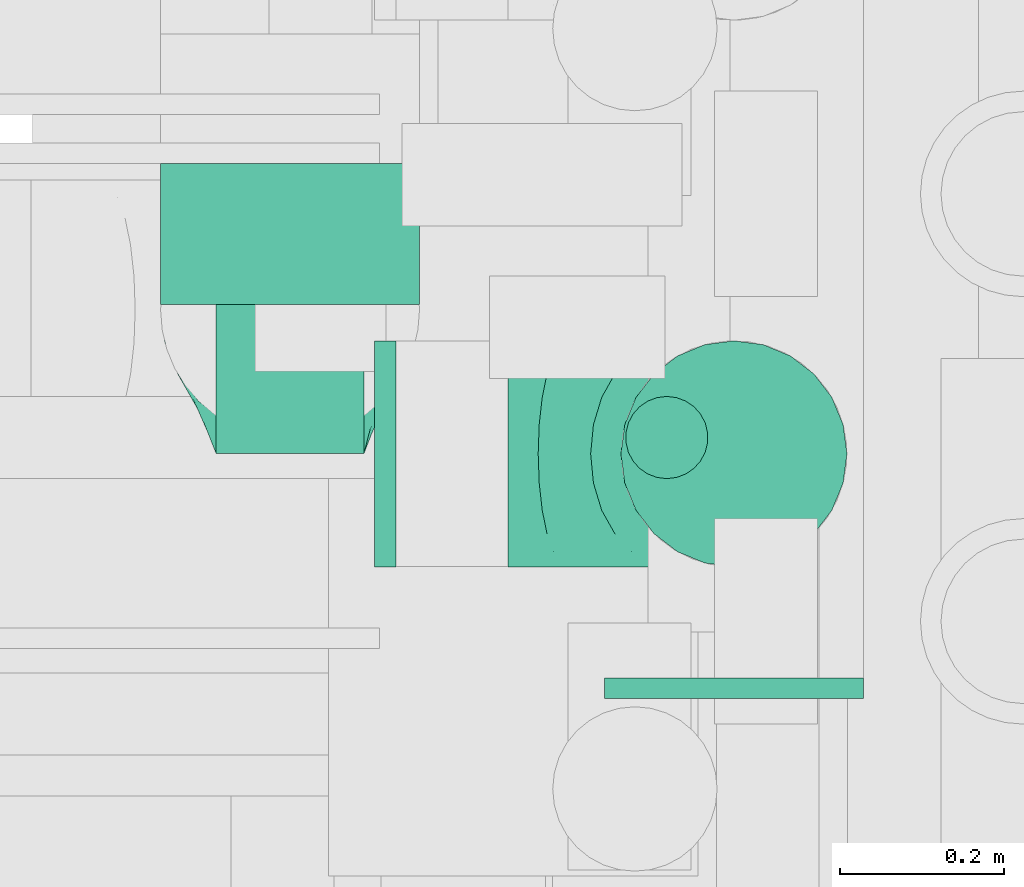
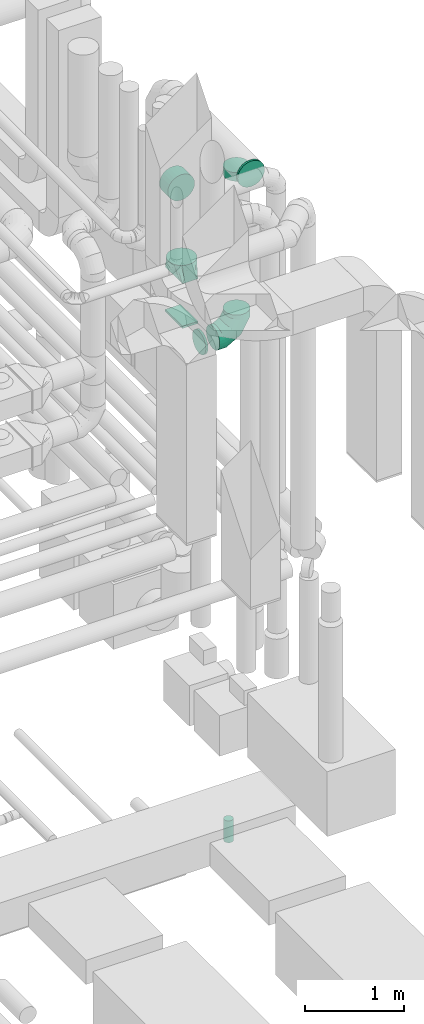
# One storey, part 306 of 337: 7 flow fittings, 1 flow segment.
"""IFC2X3 building model written with IfcOpenShell, lengths in millimetres."""

from ifc_helpers import new_model, entity, si_unit, converted_unit, derived_unit, direction, frame, origin, origin_2d_with_axis, place, context, subcontext, project, spatial, rectangle, circle, extrude, faceted_brep, source, transform, mapped, material, type_object, type_shapes, element, save


model = new_model("IFC2X3")

# Units and contexts
model_context = context("Model", 3, precision=0.01, world=origin(), true_north=direction((6.12303176911189e-17, 1.0)))
body_context = subcontext(model_context, "Body", "Model", "MODEL_VIEW")
ifc_project = project(units=[si_unit("LENGTHUNIT", "METRE", prefix="MILLI"), si_unit("AREAUNIT", "SQUARE_METRE"), si_unit("VOLUMEUNIT", "CUBIC_METRE"), converted_unit("PLANEANGLEUNIT", "DEGREE", entity("IfcRatioMeasure", 0.0174532925199433), si_unit("PLANEANGLEUNIT", "RADIAN"), dimensions=[0, 0, 0, 0, 0, 0, 0]), si_unit("MASSUNIT", "GRAM", prefix="KILO"), derived_unit("MASSDENSITYUNIT", [(si_unit("MASSUNIT", "GRAM", prefix="KILO"), 1), (si_unit("LENGTHUNIT", "METRE"), -3)]), derived_unit("MOMENTOFINERTIAUNIT", [(si_unit("LENGTHUNIT", "METRE"), 4)]), si_unit("TIMEUNIT", "SECOND"), si_unit("FREQUENCYUNIT", "HERTZ"), si_unit("THERMODYNAMICTEMPERATUREUNIT", "DEGREE_CELSIUS"), derived_unit("THERMALTRANSMITTANCEUNIT", [(si_unit("MASSUNIT", "GRAM", prefix="KILO"), 1), (si_unit("THERMODYNAMICTEMPERATUREUNIT", "KELVIN"), -1), (si_unit("TIMEUNIT", "SECOND"), -3)]), derived_unit("VOLUMETRICFLOWRATEUNIT", [(si_unit("LENGTHUNIT", "METRE"), 3), (si_unit("TIMEUNIT", "SECOND"), -1)]), derived_unit("MASSFLOWRATEUNIT", [(si_unit("MASSUNIT", "GRAM", prefix="KILO"), 1), (si_unit("TIMEUNIT", "SECOND"), -1)]), derived_unit("ROTATIONALFREQUENCYUNIT", [(si_unit("TIMEUNIT", "SECOND"), -1)]), si_unit("ELECTRICCURRENTUNIT", "AMPERE"), si_unit("ELECTRICVOLTAGEUNIT", "VOLT"), si_unit("POWERUNIT", "WATT"), si_unit("FORCEUNIT", "NEWTON", prefix="KILO"), si_unit("ILLUMINANCEUNIT", "LUX"), si_unit("LUMINOUSFLUXUNIT", "LUMEN"), si_unit("LUMINOUSINTENSITYUNIT", "CANDELA"), derived_unit("USERDEFINED", [(si_unit("MASSUNIT", "GRAM", prefix="KILO"), -1), (si_unit("LENGTHUNIT", "METRE"), -2), (si_unit("TIMEUNIT", "SECOND"), 3), (si_unit("LUMINOUSFLUXUNIT", "LUMEN"), 1)]), derived_unit("LINEARVELOCITYUNIT", [(si_unit("LENGTHUNIT", "METRE"), 1), (si_unit("TIMEUNIT", "SECOND"), -1)]), si_unit("PRESSUREUNIT", "PASCAL"), derived_unit("USERDEFINED", [(si_unit("LENGTHUNIT", "METRE"), -2), (si_unit("MASSUNIT", "GRAM", prefix="KILO"), 1), (si_unit("TIMEUNIT", "SECOND"), -2)]), derived_unit("LINEARFORCEUNIT", [(si_unit("MASSUNIT", "GRAM", prefix="KILO"), 1), (si_unit("LENGTHUNIT", "METRE"), 1), (si_unit("TIMEUNIT", "SECOND"), -2), (si_unit("LENGTHUNIT", "METRE"), -1)]), derived_unit("PLANARFORCEUNIT", [(si_unit("MASSUNIT", "GRAM", prefix="KILO"), 1), (si_unit("LENGTHUNIT", "METRE"), 1), (si_unit("TIMEUNIT", "SECOND"), -2), (si_unit("LENGTHUNIT", "METRE"), -2)])], contexts=[model_context])

# Site, building, storey
site_placement = place(None, origin())
site = spatial("IfcSite", under=ifc_project, at=site_placement, CompositionType="ELEMENT")
building_placement = place(site_placement, origin())
building = spatial("IfcBuilding", under=site, at=building_placement, CompositionType="ELEMENT")
storey_placement = place(building_placement, origin())
storey = spatial("IfcBuildingStorey", under=building, at=storey_placement, CompositionType="ELEMENT", Elevation=0.0)

# Flow segment
duct_segment_type = type_object("IfcDuctSegmentType", PredefinedType="NOTDEFINED")
flow_segment_placement = place(storey_placement, frame((72609.78, 10158.38, 26950.0)))
element("IfcFlowSegment", 1, at=flow_segment_placement, inside=storey, type_object=duct_segment_type, context=body_context, shape_type="SweptSolid", body=[
    extrude(circle(Radius=50.0, at=origin_2d_with_axis()), frame((51.6, 51.6, 0.0), z_axis=(0.0, 0.0, 1.0), x_axis=(0.0, 1.0, 0.0)), (0.0, 0.0, 1.0), 270.000000000034),
])

# Flow fittings
ifc_material = material()
duct_fitting_type_1 = type_object("IfcDuctFittingType", PredefinedType="NOTDEFINED", material=ifc_material)
shared_shape_1 = source(origin(), body_context, "Body", "SweptSolid", [
    extrude(circle(Radius=157.499999999999, at=origin_2d_with_axis()), frame((0.0, 0.0, 0.0), z_axis=(1.0, 0.0, 0.0), x_axis=(0.0, 1.0, 0.0)), (0.0, 0.0, 1.0), 25.0000000000018),
])
type_shapes(duct_fitting_type_1, [shared_shape_1])
flow_fitting_1_placement = place(storey_placement, frame((72743.11, 9917.65, 35340.0), z_axis=(0.0, 0.0, 1.0), x_axis=(0.0, -1.0, 0.0)))
element("IfcFlowFitting", 2, at=flow_fitting_1_placement, inside=storey, type_object=duct_fitting_type_1, material=ifc_material, context=body_context, shape_type="MappedRepresentation", body=[
    mapped(shared_shape_1, transform((0.0, 0.0, 0.0), scale=1.0)),
])
duct_fitting_type_2 = type_object("IfcDuctFittingType", PredefinedType="NOTDEFINED", material=ifc_material)
shared_shape_2 = source(origin(), body_context, "Body", "SweptSolid", [
    extrude(rectangle(XDim=180.0, YDim=26.096, at=origin_2d_with_axis()), frame((6.95, 0.0, -175.0), z_axis=(0.0, 0.0, 1.0), x_axis=(0.0, -1.0, 0.0)), (0.0, 0.0, 1.0), 350.0),
])
type_shapes(duct_fitting_type_2, [shared_shape_2])
flow_fitting_2_placement = place(storey_placement, frame((72203.11, 10365.65, 33475.0), z_axis=(0.0, 1.0, 0.0), x_axis=(0.0, 0.0, 1.0)))
element("IfcFlowFitting", 3, at=flow_fitting_2_placement, inside=storey, type_object=duct_fitting_type_2, material=ifc_material, context=body_context, shape_type="MappedRepresentation", body=[
    mapped(shared_shape_2, transform((0.0, 0.0, 0.0), scale=1.0)),
])
duct_fitting_type_3 = type_object("IfcDuctFittingType", PredefinedType="NOTDEFINED", material=ifc_material)
shared_shape_3 = source(origin(), body_context, "Body", "Brep", [
    faceted_brep([(20.0, 40.76, -152.13), (20.0, 78.75, -136.4), (20.0, 111.37, -111.37), (20.0, 136.4, -78.75), (20.0, 152.13, -40.76), (20.0, 157.5, 0.0), (20.0, 152.13, 40.76), (20.0, 136.4, 78.75), (20.0, 111.37, 111.37), (20.0, 78.75, 136.4), (20.0, 40.76, 152.13), (20.0, 0.0, 157.5), (20.0, -40.76, 152.13), (20.0, -78.75, 136.4), (20.0, -111.37, 111.37), (20.0, -136.4, 78.75), (20.0, -152.13, 40.76), (20.0, -157.5, 0.0), (20.0, -152.13, -40.76), (20.0, -136.4, -78.75), (20.0, -111.37, -111.37), (20.0, -78.75, -136.4), (20.0, -40.76, -152.13), (20.0, 0.0, -157.5), (0.0, 0.0, 157.5), (0.0, 40.76, 152.13), (-151.4, 40.76, 152.13), (-151.4, 0.0, 157.5), (0.0, 78.75, 136.4), (-151.4, 78.75, 136.4), (0.0, 111.37, 111.37), (-151.4, 111.37, 111.37), (0.0, 136.4, 78.75), (0.0, 152.13, 40.76), (-151.4, 152.13, 40.76), (-151.4, 136.4, 78.75), (0.0, 157.5, 0.0), (-151.4, 157.5, 0.0), (0.0, 152.13, -40.76), (-151.4, 152.13, -40.76), (0.0, 136.4, -78.75), (-151.4, 136.4, -78.75), (0.0, 111.37, -111.37), (-151.4, 111.37, -111.37), (0.0, 0.0, -157.5), (-151.4, 0.0, -157.5), (-151.4, 40.76, -152.13), (0.0, 40.76, -152.13), (-151.4, 78.75, -136.4), (0.0, 78.75, -136.4), (0.0, -40.76, -152.13), (-151.4, -40.76, -152.13), (0.0, -78.75, -136.4), (-151.4, -78.75, -136.4), (0.0, -111.37, -111.37), (-151.4, -111.37, -111.37), (0.0, -136.4, -78.75), (0.0, -152.13, -40.76), (-151.4, -152.13, -40.76), (-151.4, -136.4, -78.75), (0.0, -157.5, 0.0), (-151.4, -157.5, 0.0), (0.0, -152.13, 40.76), (-151.4, -152.13, 40.76), (0.0, -136.4, 78.75), (-151.4, -136.4, 78.75), (0.0, -111.37, 111.37), (-151.4, -111.37, 111.37), (0.0, -78.75, 136.4), (0.0, -40.76, 152.13), (-151.4, -40.76, 152.13), (-151.4, -78.75, 136.4)], [[[0, 1, 2, 3, 4, 5, 6, 7, 8, 9, 10, 11, 12, 13, 14, 15, 16, 17, 18, 19, 20, 21, 22, 23]], [[24, 11, 10, 25, 26, 27]], [[25, 10, 9, 28, 29, 26]], [[28, 9, 8, 30, 31, 29]], [[32, 7, 6, 33, 34, 35]], [[33, 6, 5, 36, 37, 34]], [[30, 8, 7, 32, 35, 31]], [[36, 5, 4, 38, 39, 37]], [[38, 4, 3, 40, 41, 39]], [[40, 3, 2, 42, 43, 41]], [[0, 23, 44, 45, 46, 47]], [[1, 0, 47, 46, 48, 49]], [[49, 48, 43, 42, 2, 1]], [[44, 23, 22, 50, 51, 45]], [[50, 22, 21, 52, 53, 51]], [[52, 21, 20, 54, 55, 53]], [[56, 19, 18, 57, 58, 59]], [[57, 18, 17, 60, 61, 58]], [[54, 20, 19, 56, 59, 55]], [[60, 17, 16, 62, 63, 61]], [[62, 16, 15, 64, 65, 63]], [[64, 15, 14, 66, 67, 65]], [[68, 13, 12, 69, 70, 71]], [[69, 12, 11, 24, 27, 70]], [[66, 14, 13, 68, 71, 67]], [[45, 51, 53, 55, 59, 58, 61, 63, 65, 67, 71, 70, 27, 26, 29, 31, 35, 34, 37, 39, 41, 43, 48, 46]]]),
])
type_shapes(duct_fitting_type_3, [shared_shape_3])
flow_fitting_3_placement = place(storey_placement, frame((72203.11, 10523.15, 35070.0), z_axis=(1.0, 0.0, 0.0), x_axis=(0.0, 1.0, 0.0)))
element("IfcFlowFitting", 4, at=flow_fitting_3_placement, inside=storey, type_object=duct_fitting_type_3, material=ifc_material, context=body_context, shape_type="MappedRepresentation", body=[
    mapped(shared_shape_3, transform((0.0, 0.0, 0.0), scale=1.0)),
])
duct_fitting_type_4 = type_object("IfcDuctFittingType", PredefinedType="NOTDEFINED", material=ifc_material)
shared_shape_4 = source(origin(), body_context, "Body", "Brep", [
    faceted_brep([(20.0, 0.0, -137.5), (20.0, 35.59, -132.81), (20.0, 68.75, -119.08), (20.0, 97.23, -97.23), (20.0, 119.08, -68.75), (20.0, 132.81, -35.59), (20.0, 137.5, 0.0), (20.0, 132.81, 35.59), (20.0, 119.08, 68.75), (20.0, 97.23, 97.23), (20.0, 68.75, 119.08), (20.0, 35.59, 132.81), (20.0, 0.0, 137.5), (20.0, -35.59, 132.81), (20.0, -68.75, 119.08), (20.0, -97.23, 97.23), (20.0, -119.08, 68.75), (20.0, -132.81, 35.59), (20.0, -137.5, 0.0), (20.0, -132.81, -35.59), (20.0, -119.08, -68.75), (20.0, -97.23, -97.23), (20.0, -68.75, -119.08), (20.0, -35.59, -132.81), (0.0, 0.0, 137.5), (-86.78, 0.0, 137.5), (-86.78, -35.59, 132.81), (0.0, -35.59, 132.81), (-86.78, -68.75, 119.08), (0.0, -68.75, 119.08), (0.0, -97.23, 97.23), (-86.78, -97.23, 97.23), (0.0, -119.08, 68.75), (-86.78, -119.08, 68.75), (-86.78, -132.81, 35.59), (0.0, -132.81, 35.59), (-86.78, -137.5, 0.0), (0.0, -137.5, 0.0), (-86.78, -132.81, -35.59), (0.0, -132.81, -35.59), (-86.78, -119.08, -68.75), (0.0, -119.08, -68.75), (0.0, -97.23, -97.23), (-86.78, -97.23, -97.23), (0.0, -68.75, -119.08), (-86.78, -68.75, -119.08), (-86.78, -35.59, -132.81), (0.0, -35.59, -132.81), (-86.78, 0.0, -137.5), (0.0, 0.0, -137.5), (-86.78, 35.59, -132.81), (0.0, 35.59, -132.81), (-86.78, 68.75, -119.08), (0.0, 68.75, -119.08), (0.0, 97.23, -97.23), (-86.78, 97.23, -97.23), (0.0, 119.08, -68.75), (-86.78, 119.08, -68.75), (-86.78, 132.81, -35.59), (0.0, 132.81, -35.59), (-86.78, 137.5, 0.0), (0.0, 137.5, 0.0), (-86.78, 132.81, 35.59), (0.0, 132.81, 35.59), (-86.78, 119.08, 68.75), (0.0, 119.08, 68.75), (0.0, 97.23, 97.23), (-86.78, 97.23, 97.23), (0.0, 68.75, 119.08), (-86.78, 68.75, 119.08), (-86.78, 35.59, 132.81), (0.0, 35.59, 132.81)], [[[0, 1, 2, 3, 4, 5, 6, 7, 8, 9, 10, 11, 12, 13, 14, 15, 16, 17, 18, 19, 20, 21, 22, 23]], [[13, 12, 24, 25, 26, 27]], [[14, 13, 27, 26, 28, 29]], [[30, 15, 14, 29, 28, 31]], [[17, 16, 32, 33, 34, 35]], [[18, 17, 35, 34, 36, 37]], [[32, 16, 15, 30, 31, 33]], [[19, 18, 37, 36, 38, 39]], [[20, 19, 39, 38, 40, 41]], [[42, 21, 20, 41, 40, 43]], [[23, 22, 44, 45, 46, 47]], [[0, 23, 47, 46, 48, 49]], [[44, 22, 21, 42, 43, 45]], [[1, 0, 49, 48, 50, 51]], [[2, 1, 51, 50, 52, 53]], [[54, 3, 2, 53, 52, 55]], [[5, 4, 56, 57, 58, 59]], [[6, 5, 59, 58, 60, 61]], [[56, 4, 3, 54, 55, 57]], [[7, 6, 61, 60, 62, 63]], [[8, 7, 63, 62, 64, 65]], [[66, 9, 8, 65, 64, 67]], [[11, 10, 68, 69, 70, 71]], [[12, 11, 71, 70, 25, 24]], [[68, 10, 9, 66, 67, 69]], [[46, 45, 43, 40, 38, 36, 34, 33, 31, 28, 26, 25, 70, 69, 67, 64, 62, 60, 58, 57, 55, 52, 50, 48]]]),
])
type_shapes(duct_fitting_type_4, [shared_shape_4])
flow_fitting_4_placement = place(storey_placement, frame((72743.11, 10190.15, 35182.5), z_axis=(0.0, 1.0, 0.0), x_axis=(0.0, 0.0, -1.0)))
element("IfcFlowFitting", 5, at=flow_fitting_4_placement, inside=storey, type_object=duct_fitting_type_4, material=ifc_material, context=body_context, shape_type="MappedRepresentation", body=[
    mapped(shared_shape_4, transform((0.0, 0.0, 0.0), scale=1.0)),
])
duct_fitting_type_5 = type_object("IfcDuctFittingType", PredefinedType="NOTDEFINED", material=ifc_material)
shared_shape_5 = source(origin(), body_context, "Body", "Brep", [
    faceted_brep([(-275.0, 0.0, -137.5), (-275.0, -35.59, -132.81), (-275.0, -68.75, -119.08), (-275.0, -97.23, -97.23), (-275.0, -119.08, -68.75), (-275.0, -132.81, -35.59), (-275.0, -137.5, 0.0), (-275.0, -132.81, 35.59), (-275.0, -119.08, 68.75), (-275.0, -97.23, 97.23), (-275.0, -68.75, 119.08), (-275.0, -35.59, 132.81), (-275.0, 0.0, 137.5), (-275.0, 35.59, 132.81), (-275.0, 68.75, 119.08), (-275.0, 97.23, 97.23), (-275.0, 119.08, 68.75), (-275.0, 132.81, 35.59), (-275.0, 137.5, 0.0), (-275.0, 132.81, -35.59), (-275.0, 119.08, -68.75), (-275.0, 97.23, -97.23), (-275.0, 68.75, -119.08), (-275.0, 35.59, -132.81), (-210.85, 35.59, 132.81), (-219.74, 68.75, 119.08), (-201.31, 0.0, 137.5), (-227.37, 97.23, 97.23), (-236.9, 132.81, 35.59), (-238.16, 137.5, 0.0), (-233.22, 119.08, 68.75), (-233.22, 119.08, -68.75), (-227.37, 97.23, -97.23), (-236.9, 132.81, -35.59), (-210.85, 35.59, -132.81), (-201.31, 0.0, -137.5), (-219.74, 68.75, -119.08), (-191.78, -35.59, -132.81), (-182.89, -68.75, -119.08), (-175.26, -97.23, -97.23), (-169.41, -119.08, -68.75), (-165.73, -132.81, -35.59), (-164.47, -137.5, 0.0), (-165.73, -132.81, 35.59), (-169.41, -119.08, 68.75), (-175.26, -97.23, 97.23), (-182.89, -68.75, 119.08), (-191.78, -35.59, 132.81), (-99.74, 99.74, 132.81), (-124.01, 124.01, 119.08), (-73.69, 73.69, 137.5), (-144.86, 144.86, 97.23), (-160.86, 160.86, 68.75), (-170.91, 170.91, 35.59), (-174.34, 174.34, 0.0), (-170.91, 170.91, -35.59), (-160.86, 160.86, -68.75), (-144.86, 144.86, -97.23), (-99.74, 99.74, -132.81), (-73.69, 73.69, -137.5), (-124.01, 124.01, -119.08), (-47.63, 47.63, -132.81), (-23.36, 23.36, -119.08), (-2.51, 2.51, -97.23), (13.49, -13.49, -68.75), (23.54, -23.54, -35.59), (26.97, -26.97, 0.0), (23.54, -23.54, 35.59), (13.49, -13.49, 68.75), (-2.51, 2.51, 97.23), (-23.36, 23.36, 119.08), (-47.63, 47.63, 132.81), (-35.59, 210.85, 132.81), (-68.75, 219.74, 119.08), (0.0, 201.31, 137.5), (-97.23, 227.37, 97.23), (-119.08, 233.22, 68.75), (-132.81, 236.9, 35.59), (-137.5, 238.16, 0.0), (-132.81, 236.9, -35.59), (-119.08, 233.22, -68.75), (-97.23, 227.37, -97.23), (-35.59, 210.85, -132.81), (0.0, 201.31, -137.5), (-68.75, 219.74, -119.08), (35.59, 191.78, -132.81), (68.75, 182.89, -119.08), (97.23, 175.26, -97.23), (119.08, 169.41, -68.75), (132.81, 165.73, -35.59), (137.5, 164.47, 0.0), (132.81, 165.73, 35.59), (119.08, 169.41, 68.75), (97.23, 175.26, 97.23), (68.75, 182.89, 119.08), (35.59, 191.78, 132.81), (-35.59, 275.0, -132.81), (-68.75, 275.0, -119.08), (-97.23, 275.0, -97.23), (-119.08, 275.0, -68.75), (-132.81, 275.0, -35.59), (-137.5, 275.0, 0.0), (-132.81, 275.0, 35.59), (-119.08, 275.0, 68.75), (-97.23, 275.0, 97.23), (-68.75, 275.0, 119.08), (-35.59, 275.0, 132.81), (0.0, 275.0, 137.5), (35.59, 275.0, 132.81), (68.75, 275.0, 119.08), (97.23, 275.0, 97.23), (119.08, 275.0, 68.75), (132.81, 275.0, 35.59), (137.5, 275.0, 0.0), (132.81, 275.0, -35.59), (119.08, 275.0, -68.75), (97.23, 275.0, -97.23), (68.75, 275.0, -119.08), (35.59, 275.0, -132.81), (0.0, 275.0, -137.5)], [[[0, 1, 2, 3, 4, 5, 6, 7, 8, 9, 10, 11, 12, 13, 14, 15, 16, 17, 18, 19, 20, 21, 22, 23]], [[24, 25, 14, 13]], [[26, 24, 13, 12]], [[14, 25, 27, 15]], [[28, 29, 18, 17]], [[30, 28, 17, 16]], [[15, 27, 30, 16]], [[20, 31, 32, 21]], [[33, 31, 20, 19]], [[18, 29, 33, 19]], [[34, 35, 0, 23]], [[36, 34, 23, 22]], [[32, 36, 22, 21]], [[1, 0, 35, 37]], [[2, 1, 37, 38]], [[38, 39, 3, 2]], [[5, 4, 40, 41]], [[6, 5, 41, 42]], [[39, 40, 4, 3]], [[6, 42, 43, 7]], [[7, 43, 44, 8]], [[8, 44, 45, 9]], [[9, 45, 46, 10]], [[10, 46, 47, 11]], [[26, 12, 11, 47]], [[48, 49, 25, 24]], [[50, 48, 24, 26]], [[27, 25, 49, 51]], [[52, 53, 28, 30]], [[51, 52, 30, 27]], [[29, 28, 53, 54]], [[55, 56, 31, 33]], [[54, 55, 33, 29]], [[32, 31, 56, 57]], [[58, 59, 35, 34]], [[60, 58, 34, 36]], [[57, 60, 36, 32]], [[37, 35, 59, 61]], [[38, 37, 61, 62]], [[39, 38, 62, 63]], [[41, 40, 64, 65]], [[42, 41, 65, 66]], [[63, 64, 40, 39]], [[43, 42, 66, 67]], [[44, 43, 67, 68]], [[68, 69, 45, 44]], [[46, 45, 69, 70]], [[47, 46, 70, 71]], [[26, 47, 71, 50]], [[72, 73, 49, 48]], [[74, 72, 48, 50]], [[51, 49, 73, 75]], [[76, 77, 53, 52]], [[75, 76, 52, 51]], [[54, 53, 77, 78]], [[79, 80, 56, 55]], [[78, 79, 55, 54]], [[57, 56, 80, 81]], [[82, 83, 59, 58]], [[84, 82, 58, 60]], [[81, 84, 60, 57]], [[61, 59, 83, 85]], [[62, 61, 85, 86]], [[63, 62, 86, 87]], [[65, 64, 88, 89]], [[66, 65, 89, 90]], [[87, 88, 64, 63]], [[67, 66, 90, 91]], [[68, 67, 91, 92]], [[92, 93, 69, 68]], [[70, 69, 93, 94]], [[71, 70, 94, 95]], [[50, 71, 95, 74]], [[96, 97, 98, 99, 100, 101, 102, 103, 104, 105, 106, 107, 108, 109, 110, 111, 112, 113, 114, 115, 116, 117, 118, 119]], [[72, 74, 107, 106]], [[73, 72, 106, 105]], [[75, 73, 105, 104]], [[77, 76, 103, 102]], [[78, 77, 102, 101]], [[104, 103, 76, 75]], [[78, 101, 100, 79]], [[79, 100, 99, 80]], [[98, 81, 80, 99]], [[84, 97, 96, 82]], [[82, 96, 119, 83]], [[97, 84, 81, 98]], [[83, 119, 118, 85]], [[85, 118, 117, 86]], [[116, 87, 86, 117]], [[88, 115, 114, 89]], [[89, 114, 113, 90]], [[115, 88, 87, 116]], [[91, 90, 113, 112]], [[92, 91, 112, 111]], [[111, 110, 93, 92]], [[95, 94, 109, 108]], [[74, 95, 108, 107]], [[110, 109, 94, 93]]]),
])
type_shapes(duct_fitting_type_5, [shared_shape_5])
flow_fitting_5_placement = place(storey_placement, frame((72743.11, 10190.15, 33235.07), z_axis=(0.0, 1.0, 0.0), x_axis=(0.0, 0.0, -1.0)))
element("IfcFlowFitting", 6, at=flow_fitting_5_placement, inside=storey, type_object=duct_fitting_type_5, material=ifc_material, context=body_context, shape_type="MappedRepresentation", body=[
    mapped(shared_shape_5, transform((0.0, 0.0, 0.0), scale=1.0)),
])
duct_fitting_type_6 = type_object("IfcDuctFittingType", PredefinedType="NOTDEFINED", material=ifc_material)
shared_shape_6 = source(origin(), body_context, "Body", "Brep", [
    faceted_brep([(20.0, 35.59, -132.81), (20.0, 68.75, -119.08), (20.0, 97.23, -97.23), (20.0, 119.08, -68.75), (20.0, 132.81, -35.59), (20.0, 137.5, 0.0), (20.0, 132.81, 35.59), (20.0, 119.08, 68.75), (20.0, 97.23, 97.23), (20.0, 68.75, 119.08), (20.0, 35.59, 132.81), (20.0, 0.0, 137.5), (20.0, -35.59, 132.81), (20.0, -68.75, 119.08), (20.0, -97.23, 97.23), (20.0, -119.08, 68.75), (20.0, -132.81, 35.59), (20.0, -137.5, 0.0), (20.0, -132.81, -35.59), (20.0, -119.08, -68.75), (20.0, -97.23, -97.23), (20.0, -68.75, -119.08), (20.0, -35.59, -132.81), (20.0, 0.0, -137.5), (0.0, 0.0, 137.5), (0.0, 35.59, 132.81), (-6.1, 35.59, 132.81), (-6.1, 0.0, 137.5), (0.0, 68.75, 119.08), (-6.1, 68.75, 119.08), (0.0, 97.23, 97.23), (-6.1, 97.23, 97.23), (0.0, 119.08, 68.75), (0.0, 132.81, 35.59), (-6.1, 132.81, 35.59), (-6.1, 119.08, 68.75), (0.0, 137.5, 0.0), (-6.1, 137.5, 0.0), (0.0, 132.81, -35.59), (-6.1, 132.81, -35.59), (0.0, 119.08, -68.75), (-6.1, 119.08, -68.75), (0.0, 97.23, -97.23), (-6.1, 97.23, -97.23), (0.0, 68.75, -119.08), (0.0, 35.59, -132.81), (-6.1, 35.59, -132.81), (-6.1, 68.75, -119.08), (0.0, 0.0, -137.5), (-6.1, 0.0, -137.5), (0.0, -35.59, -132.81), (-6.1, -35.59, -132.81), (0.0, -68.75, -119.08), (-6.1, -68.75, -119.08), (0.0, -97.23, -97.23), (-6.1, -97.23, -97.23), (0.0, -119.08, -68.75), (0.0, -132.81, -35.59), (-6.1, -132.81, -35.59), (-6.1, -119.08, -68.75), (0.0, -137.5, 0.0), (-6.1, -137.5, 0.0), (0.0, -132.81, 35.59), (-6.1, -132.81, 35.59), (0.0, -119.08, 68.75), (-6.1, -119.08, 68.75), (0.0, -97.23, 97.23), (-6.1, -97.23, 97.23), (0.0, -68.75, 119.08), (0.0, -35.59, 132.81), (-6.1, -35.59, 132.81), (-6.1, -68.75, 119.08)], [[[0, 1, 2, 3, 4, 5, 6, 7, 8, 9, 10, 11, 12, 13, 14, 15, 16, 17, 18, 19, 20, 21, 22, 23]], [[24, 11, 10, 25, 26, 27]], [[25, 10, 9, 28, 29, 26]], [[28, 9, 8, 30, 31, 29]], [[32, 7, 6, 33, 34, 35]], [[33, 6, 5, 36, 37, 34]], [[30, 8, 7, 32, 35, 31]], [[36, 5, 4, 38, 39, 37]], [[38, 4, 3, 40, 41, 39]], [[40, 3, 2, 42, 43, 41]], [[44, 1, 0, 45, 46, 47]], [[45, 0, 23, 48, 49, 46]], [[42, 2, 1, 44, 47, 43]], [[48, 23, 22, 50, 51, 49]], [[50, 22, 21, 52, 53, 51]], [[52, 21, 20, 54, 55, 53]], [[56, 19, 18, 57, 58, 59]], [[57, 18, 17, 60, 61, 58]], [[54, 20, 19, 56, 59, 55]], [[60, 17, 16, 62, 63, 61]], [[62, 16, 15, 64, 65, 63]], [[64, 15, 14, 66, 67, 65]], [[68, 13, 12, 69, 70, 71]], [[69, 12, 11, 24, 27, 70]], [[66, 14, 13, 68, 71, 67]], [[49, 51, 53, 55, 59, 58, 61, 63, 65, 67, 71, 70, 27, 26, 29, 31, 35, 34, 37, 39, 41, 43, 47, 46]]]),
])
type_shapes(duct_fitting_type_6, [shared_shape_6])
flow_fitting_6_placement = place(storey_placement, frame((72311.99, 10190.15, 33235.07), z_axis=(0.0, 0.0, -1.0), x_axis=(1.0, 0.0, 0.0)))
element("IfcFlowFitting", 7, at=flow_fitting_6_placement, inside=storey, type_object=duct_fitting_type_6, material=ifc_material, context=body_context, shape_type="MappedRepresentation", body=[
    mapped(shared_shape_6, transform((0.0, 0.0, 0.0), scale=1.0)),
])
duct_fitting_type_7 = type_object("IfcDuctFittingType", PredefinedType="NOTDEFINED", material=ifc_material)
shared_shape_7 = source(origin(), body_context, "Body", "Brep", [
    faceted_brep([(200.0, 78.75, 136.4), (200.0, 59.76, 144.27), (200.0, 40.76, 152.13), (200.0, 27.93, 153.82), (200.0, 15.1, 155.51), (200.0, 0.0, 157.5), (200.0, -15.1, 155.51), (200.0, -27.93, 153.82), (200.0, -40.76, 152.13), (200.0, -59.76, 144.27), (200.0, -78.75, 136.4), (200.0, -95.06, 123.88), (200.0, -111.37, 111.37), (200.0, -123.88, 95.06), (200.0, -136.4, 78.75), (200.0, -144.27, 59.76), (200.0, -152.13, 40.76), (200.0, -153.82, 27.93), (200.0, -155.51, 15.1), (200.0, -157.5, 0.0), (200.0, -155.51, -15.1), (200.0, -153.82, -27.93), (200.0, -152.13, -40.76), (200.0, -144.27, -59.76), (200.0, -136.4, -78.75), (200.0, -123.88, -95.06), (200.0, -111.37, -111.37), (200.0, -95.06, -123.88), (200.0, -78.75, -136.4), (200.0, -59.76, -144.27), (200.0, -40.76, -152.13), (200.0, -27.93, -153.82), (200.0, -15.1, -155.51), (200.0, 0.0, -157.5), (200.0, 15.1, -155.51), (200.0, 27.93, -153.82), (200.0, 40.76, -152.13), (200.0, 59.76, -144.27), (200.0, 78.75, -136.4), (200.0, 95.06, -123.88), (200.0, 111.37, -111.37), (200.0, 123.88, -95.06), (200.0, 136.4, -78.75), (200.0, 144.27, -59.76), (200.0, 152.13, -40.76), (200.0, 153.82, -27.93), (200.0, 155.51, -15.1), (200.0, 157.5, 0.0), (200.0, 155.51, 15.1), (200.0, 153.82, 27.93), (200.0, 152.13, 40.76), (200.0, 144.27, 59.76), (200.0, 136.4, 78.75), (200.0, 123.88, 95.06), (200.0, 111.37, 111.37), (200.0, 95.06, 123.88), (0.0, -90.0, 175.0), (0.0, 90.0, 175.0), (0.0, 90.0, -175.0), (0.0, -90.0, -175.0), (128.09, -32.36, 163.79), (104.11, -43.15, 165.89), (78.09, -54.86, 168.17), (100.0, -97.21, 146.45), (26.03, -78.29, 172.72), (52.06, -107.57, 129.45), (26.03, -98.78, 152.23), (78.09, -116.35, 106.68), (104.11, -125.14, 83.9), (128.09, -133.23, 62.93), (176.03, -10.79, 159.6), (152.06, -21.57, 161.7), (152.06, -141.32, 41.95), (176.03, -149.41, 20.98), (52.06, -66.57, 170.45), (26.03, -98.78, -152.23), (52.06, -107.57, -129.45), (78.09, -116.35, -106.68), (104.11, -125.14, -83.9), (128.09, -133.23, -62.93), (152.06, -141.32, -41.95), (176.03, -149.41, -20.98), (100.0, -103.95, -139.71), (52.06, -66.57, -170.45), (26.03, -78.29, -172.72), (78.09, -54.86, -168.17), (104.11, -43.15, -165.89), (128.09, -32.36, -163.79), (152.06, -21.57, -161.7), (176.03, -10.79, -159.6), (26.03, 78.29, -172.72), (52.06, 66.57, -170.45), (78.09, 54.86, -168.17), (104.11, 43.15, -165.89), (128.09, 32.36, -163.79), (152.06, 21.57, -161.7), (176.03, 10.79, -159.6), (100.0, 97.21, -146.45), (52.06, 107.57, -129.45), (26.03, 98.78, -152.23), (78.09, 116.35, -106.68), (104.11, 125.14, -83.9), (128.09, 133.23, -62.93), (152.06, 141.32, -41.95), (176.03, 149.41, -20.98), (26.03, 98.78, 152.23), (52.06, 107.57, 129.45), (78.09, 116.35, 106.68), (104.11, 125.14, 83.9), (128.09, 133.23, 62.93), (152.06, 141.32, 41.95), (176.03, 149.41, 20.98), (100.0, 103.95, 139.71), (52.06, 66.57, 170.45), (26.03, 78.29, 172.72), (78.09, 54.86, 168.17), (104.11, 43.15, 165.89), (128.09, 32.36, 163.79), (152.06, 21.57, 161.7), (176.03, 10.79, 159.6)], [[[0, 1, 2, 3, 4, 5, 6, 7, 8, 9, 10, 11, 12, 13, 14, 15, 16, 17, 18, 19, 20, 21, 22, 23, 24, 25, 26, 27, 28, 29, 30, 31, 32, 33, 34, 35, 36, 37, 38, 39, 40, 41, 42, 43, 44, 45, 46, 47, 48, 49, 50, 51, 52, 53, 54, 55]], [[56, 57, 58, 59]], [[60, 61, 62, 9]], [[63, 11, 64]], [[13, 12, 63]], [[8, 60, 9]], [[9, 62, 10]], [[65, 14, 13]], [[13, 63, 66]], [[15, 67, 68, 69]], [[70, 71, 60, 8, 7, 6, 5]], [[17, 16, 69, 72, 73, 19, 18]], [[15, 14, 67]], [[15, 69, 16]], [[14, 65, 67]], [[11, 74, 64]], [[11, 10, 74]], [[56, 63, 64]], [[11, 63, 12]], [[13, 66, 65]], [[63, 56, 66]], [[62, 74, 10]], [[73, 72, 69, 68, 67, 65, 66, 56, 59, 75, 76, 77, 78, 79, 80, 81, 19]], [[79, 78, 77, 23]], [[82, 25, 75]], [[27, 26, 82]], [[22, 79, 23]], [[23, 77, 24]], [[83, 28, 27]], [[27, 82, 84]], [[29, 85, 86, 87]], [[81, 80, 79, 22, 21, 20, 19]], [[31, 30, 87, 88, 89, 33, 32]], [[29, 28, 85]], [[29, 87, 30]], [[28, 83, 85]], [[25, 76, 75]], [[25, 24, 76]], [[59, 82, 75]], [[25, 82, 26]], [[27, 84, 83]], [[82, 59, 84]], [[77, 76, 24]], [[89, 88, 87, 86, 85, 83, 84, 59, 58, 90, 91, 92, 93, 94, 95, 96, 33]], [[94, 93, 92, 37]], [[97, 39, 90]], [[41, 40, 97]], [[36, 94, 37]], [[37, 92, 38]], [[98, 42, 41]], [[41, 97, 99]], [[43, 100, 101, 102]], [[96, 95, 94, 36, 35, 34, 33]], [[45, 44, 102, 103, 104, 47, 46]], [[43, 42, 100]], [[43, 102, 44]], [[42, 98, 100]], [[39, 91, 90]], [[39, 38, 91]], [[58, 97, 90]], [[39, 97, 40]], [[41, 99, 98]], [[97, 58, 99]], [[92, 91, 38]], [[58, 57, 105, 106, 107, 108, 109, 110, 111, 47, 104, 103, 102, 101, 100, 98, 99]], [[109, 108, 107, 51]], [[112, 53, 105]], [[55, 54, 112]], [[50, 109, 51]], [[51, 107, 52]], [[113, 0, 55]], [[55, 112, 114]], [[1, 115, 116, 117]], [[111, 110, 109, 50, 49, 48, 47]], [[3, 2, 117, 118, 119, 5, 4]], [[1, 0, 115]], [[1, 117, 2]], [[0, 113, 115]], [[53, 106, 105]], [[53, 52, 106]], [[57, 112, 105]], [[53, 112, 54]], [[55, 114, 113]], [[112, 57, 114]], [[107, 106, 52]], [[57, 56, 64, 74, 62, 61, 60, 71, 70, 5, 119, 118, 117, 116, 115, 113, 114]]]),
])
type_shapes(duct_fitting_type_7, [shared_shape_7])
flow_fitting_7_placement = place(storey_placement, frame((72203.11, 10365.65, 34020.0), z_axis=(0.0, 1.0, 0.0), x_axis=(0.0, 0.0, 1.0)))
element("IfcFlowFitting", 8, at=flow_fitting_7_placement, inside=storey, type_object=duct_fitting_type_7, material=ifc_material, context=body_context, shape_type="MappedRepresentation", body=[
    mapped(shared_shape_7, transform((0.0, 0.0, 0.0), scale=1.0)),
])

save(model, "model.ifc")
